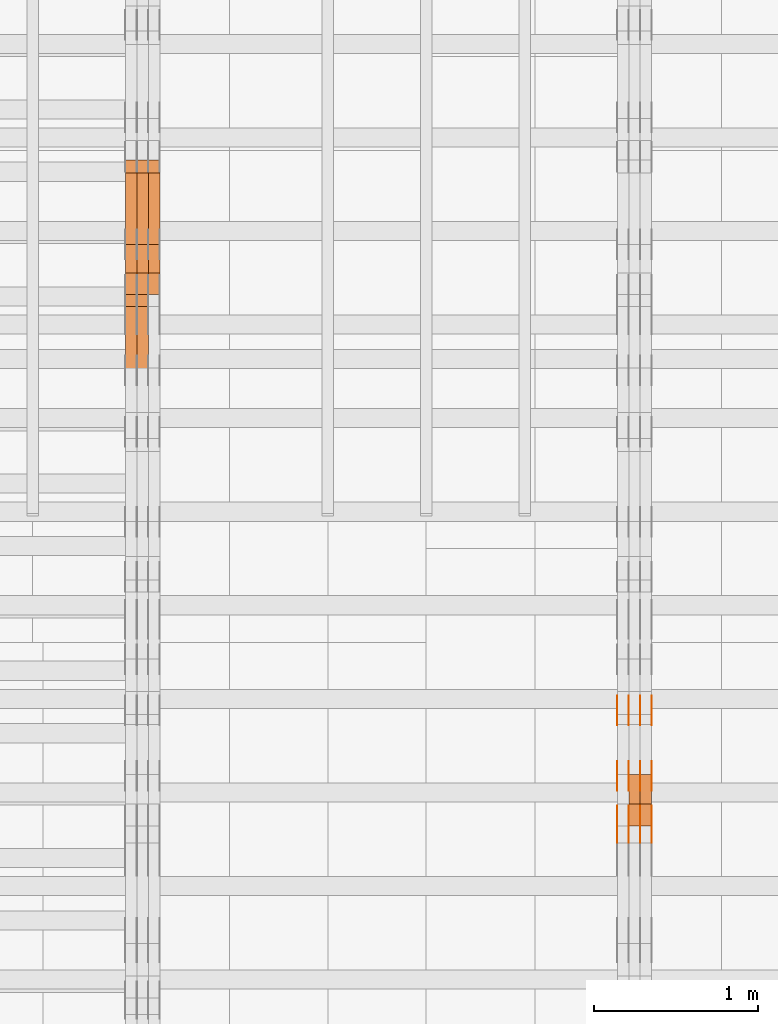
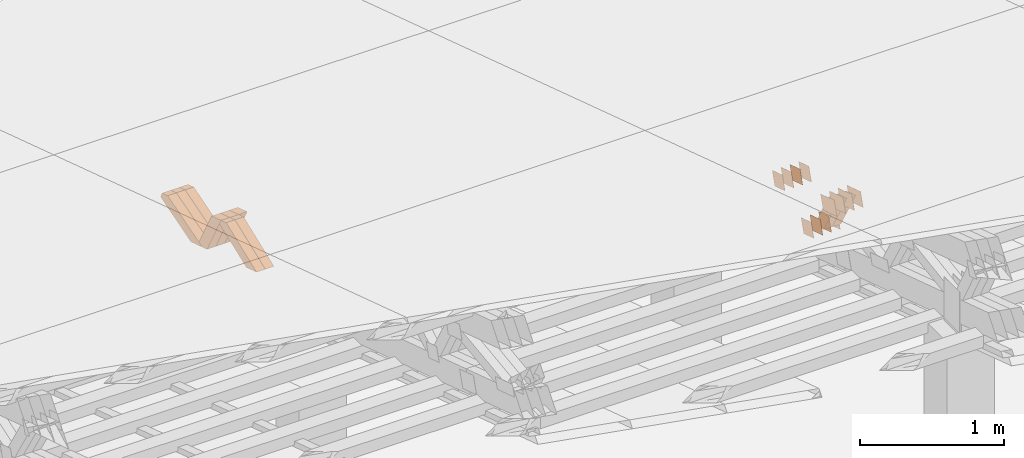
# One storey, part 177 of 385: 28 proxies.
"""IFC2X3 building model written with IfcOpenShell, lengths in millimetres."""

from ifc_helpers import new_model, entity, si_unit, converted_unit, derived_unit, direction, frame, origin, place, context, subcontext, project, spatial, polyline, outline, extrude, source, transform, mapped, material, type_object, type_shapes, element, save


model = new_model("IFC2X3")

# Units and contexts
model_context = context("Model", 3, precision=0.01, world=origin(), true_north=direction((6.12303176911189e-17, 1.0)))
body_context = subcontext(model_context, "Body", "Model", "MODEL_VIEW")
ifc_project = project(units=[si_unit("LENGTHUNIT", "METRE", prefix="MILLI"), si_unit("AREAUNIT", "SQUARE_METRE"), si_unit("VOLUMEUNIT", "CUBIC_METRE"), converted_unit("PLANEANGLEUNIT", "DEGREE", entity("IfcRatioMeasure", 0.0174532925199433), si_unit("PLANEANGLEUNIT", "RADIAN"), dimensions=[0, 0, 0, 0, 0, 0, 0]), si_unit("MASSUNIT", "GRAM", prefix="KILO"), derived_unit("MASSDENSITYUNIT", [(si_unit("MASSUNIT", "GRAM", prefix="KILO"), 1), (si_unit("LENGTHUNIT", "METRE"), -3)]), si_unit("TIMEUNIT", "SECOND"), si_unit("FREQUENCYUNIT", "HERTZ"), si_unit("THERMODYNAMICTEMPERATUREUNIT", "DEGREE_CELSIUS"), derived_unit("THERMALTRANSMITTANCEUNIT", [(si_unit("MASSUNIT", "GRAM", prefix="KILO"), 1), (si_unit("THERMODYNAMICTEMPERATUREUNIT", "KELVIN"), -1), (si_unit("TIMEUNIT", "SECOND"), -3)]), derived_unit("VOLUMETRICFLOWRATEUNIT", [(si_unit("LENGTHUNIT", "METRE"), 3), (si_unit("TIMEUNIT", "SECOND"), -1)]), si_unit("ELECTRICCURRENTUNIT", "AMPERE"), si_unit("ELECTRICVOLTAGEUNIT", "VOLT"), si_unit("POWERUNIT", "WATT"), si_unit("FORCEUNIT", "NEWTON", prefix="KILO"), si_unit("ILLUMINANCEUNIT", "LUX"), si_unit("LUMINOUSFLUXUNIT", "LUMEN"), si_unit("LUMINOUSINTENSITYUNIT", "CANDELA"), derived_unit("USERDEFINED", [(si_unit("MASSUNIT", "GRAM", prefix="KILO"), -1), (si_unit("LENGTHUNIT", "METRE"), -2), (si_unit("TIMEUNIT", "SECOND"), 3), (si_unit("LUMINOUSFLUXUNIT", "LUMEN"), 1)]), derived_unit("LINEARVELOCITYUNIT", [(si_unit("LENGTHUNIT", "METRE"), 1), (si_unit("TIMEUNIT", "SECOND"), -1)]), si_unit("PRESSUREUNIT", "PASCAL"), derived_unit("USERDEFINED", [(si_unit("LENGTHUNIT", "METRE"), -2), (si_unit("MASSUNIT", "GRAM", prefix="KILO"), 1), (si_unit("TIMEUNIT", "SECOND"), -2)])], contexts=[model_context])

# Site, building, storey
site_placement = place(None, origin())
site = spatial("IfcSite", under=ifc_project, at=site_placement, CompositionType="ELEMENT")
building_placement = place(site_placement, origin())
building = spatial("IfcBuilding", under=site, at=building_placement, CompositionType="ELEMENT")
storey_placement = place(building_placement, origin())
storey = spatial("IfcBuildingStorey", under=building, at=storey_placement, Name="Default", CompositionType="ELEMENT", Elevation=0.0)

# Proxies
ifc_material_1 = material(Name="IfcSurfaceStyle #107554")
building_element_proxy_type_1 = type_object("IfcBuildingElementProxyType", PredefinedType="NOTDEFINED", material=ifc_material_1)
shared_shape_1 = source(origin(), body_context, "Body", "SweptSolid", [
    extrude(outline(polyline([(-74.9998982809088, -60.000042563519), (74.9998377068237, -60.000042563519), (74.9998982809079, 60.0000425635189), (-74.9998377068227, 60.0000425635189), (-74.9998982809088, -60.000042563519)])), frame((75.0001050385304, 60.0001177331169, 0.0), z_axis=(0.0, 0.0, 1.0), x_axis=(-1.0, 0.0, 0.0)), (0.0, 0.0, 1.0), 1.3),
])
type_shapes(building_element_proxy_type_1, [shared_shape_1])
proxy_1_placement = place(building_placement, frame((6386.29999999999, 19806.7306653882, 2506.65203571776), z_axis=(-1.0, 0.0, 0.0), x_axis=(0.0, -0.951056516295154, 0.309016994374948)))
element("IfcBuildingElementProxy", 1, at=proxy_1_placement, inside=storey, type_object=building_element_proxy_type_1, material=ifc_material_1, context=body_context, shape_type="MappedRepresentation", body=[
    mapped(shared_shape_1, transform((0.0, 0.0, 0.0), scale=1.0)),
])
ifc_material_2 = material(Name="IfcSurfaceStyle #107497")
building_element_proxy_type_2 = type_object("IfcBuildingElementProxyType", PredefinedType="NOTDEFINED", material=ifc_material_2)
shared_shape_2 = source(origin(), body_context, "Body", "SweptSolid", [
    extrude(outline(polyline([(-74.9998982809088, -60.000042563519), (74.9998377068237, -60.000042563519), (74.9998982809079, 60.0000425635189), (-74.9998377068227, 60.0000425635189), (-74.9998982809088, -60.000042563519)])), frame((75.0001050385304, 60.0001177331169, 0.0), z_axis=(0.0, 0.0, 1.0), x_axis=(-1.0, 0.0, 0.0)), (0.0, 0.0, 1.0), 1.3),
])
type_shapes(building_element_proxy_type_2, [shared_shape_2])
proxy_2_placement = place(building_placement, frame((6315.0, 19806.7306653882, 2506.65203571776), z_axis=(-1.0, 0.0, 0.0), x_axis=(0.0, -0.951056516295154, 0.309016994374948)))
element("IfcBuildingElementProxy", 2, at=proxy_2_placement, inside=storey, type_object=building_element_proxy_type_2, material=ifc_material_2, context=body_context, shape_type="MappedRepresentation", body=[
    mapped(shared_shape_2, transform((0.0, 0.0, 0.0), scale=1.0)),
])
ifc_material_3 = material(Name="IfcSurfaceStyle #107440")
building_element_proxy_type_3 = type_object("IfcBuildingElementProxyType", PredefinedType="NOTDEFINED", material=ifc_material_3)
shared_shape_3 = source(origin(), body_context, "Body", "SweptSolid", [
    extrude(outline(polyline([(-74.9998982809088, -60.000042563519), (74.9998377068237, -60.000042563519), (74.9998982809079, 60.0000425635189), (-74.9998377068227, 60.0000425635189), (-74.9998982809088, -60.000042563519)])), frame((75.0001050385304, 60.0001177331169, 0.0), z_axis=(0.0, 0.0, 1.0), x_axis=(-1.0, 0.0, 0.0)), (0.0, 0.0, 1.0), 1.3),
])
type_shapes(building_element_proxy_type_3, [shared_shape_3])
proxy_3_placement = place(building_placement, frame((6316.29999999999, 19806.7306653882, 2506.65203571776), z_axis=(-1.0, 0.0, 0.0), x_axis=(0.0, -0.951056516295154, 0.309016994374948)))
element("IfcBuildingElementProxy", 3, at=proxy_3_placement, inside=storey, type_object=building_element_proxy_type_3, material=ifc_material_3, context=body_context, shape_type="MappedRepresentation", body=[
    mapped(shared_shape_3, transform((0.0, 0.0, 0.0), scale=1.0)),
])
ifc_material_4 = material(Name="IfcSurfaceStyle #107383")
building_element_proxy_type_4 = type_object("IfcBuildingElementProxyType", PredefinedType="NOTDEFINED", material=ifc_material_4)
shared_shape_4 = source(origin(), body_context, "Body", "SweptSolid", [
    extrude(outline(polyline([(-74.9998982809088, -60.000042563519), (74.9998377068237, -60.000042563519), (74.9998982809079, 60.0000425635189), (-74.9998377068227, 60.0000425635189), (-74.9998982809088, -60.000042563519)])), frame((75.0001050385304, 60.0001177331169, 0.0), z_axis=(0.0, 0.0, 1.0), x_axis=(-1.0, 0.0, 0.0)), (0.0, 0.0, 1.0), 1.29999999999999),
])
type_shapes(building_element_proxy_type_4, [shared_shape_4])
proxy_4_placement = place(building_placement, frame((6245.0, 19806.7306653882, 2506.65203571776), z_axis=(-1.0, 0.0, 0.0), x_axis=(0.0, -0.951056516295154, 0.309016994374948)))
element("IfcBuildingElementProxy", 4, at=proxy_4_placement, inside=storey, type_object=building_element_proxy_type_4, material=ifc_material_4, context=body_context, shape_type="MappedRepresentation", body=[
    mapped(shared_shape_4, transform((0.0, 0.0, 0.0), scale=1.0)),
])
ifc_material_5 = material(Name="IfcSurfaceStyle #107326")
building_element_proxy_type_5 = type_object("IfcBuildingElementProxyType", PredefinedType="NOTDEFINED", material=ifc_material_5)
shared_shape_5 = source(origin(), body_context, "Body", "SweptSolid", [
    extrude(outline(polyline([(-74.9998982809088, -60.000042563519), (74.9998377068237, -60.000042563519), (74.9998982809079, 60.0000425635189), (-74.9998377068227, 60.0000425635189), (-74.9998982809088, -60.000042563519)])), frame((75.0001050385304, 60.0001177331169, 0.0), z_axis=(0.0, 0.0, 1.0), x_axis=(-1.0, 0.0, 0.0)), (0.0, 0.0, 1.0), 1.29999999999999),
])
type_shapes(building_element_proxy_type_5, [shared_shape_5])
proxy_5_placement = place(building_placement, frame((6246.29999999999, 19806.7306653882, 2506.65203571776), z_axis=(-1.0, 0.0, 0.0), x_axis=(0.0, -0.951056516295154, 0.309016994374948)))
element("IfcBuildingElementProxy", 5, at=proxy_5_placement, inside=storey, type_object=building_element_proxy_type_5, material=ifc_material_5, context=body_context, shape_type="MappedRepresentation", body=[
    mapped(shared_shape_5, transform((0.0, 0.0, 0.0), scale=1.0)),
])
ifc_material_6 = material(Name="IfcSurfaceStyle #107269")
building_element_proxy_type_6 = type_object("IfcBuildingElementProxyType", PredefinedType="NOTDEFINED", material=ifc_material_6)
shared_shape_6 = source(origin(), body_context, "Body", "SweptSolid", [
    extrude(outline(polyline([(-74.9998982809088, -60.000042563519), (74.9998377068237, -60.000042563519), (74.9998982809079, 60.0000425635189), (-74.9998377068227, 60.0000425635189), (-74.9998982809088, -60.000042563519)])), frame((75.0001050385304, 60.0001177331169, 0.0), z_axis=(0.0, 0.0, 1.0), x_axis=(-1.0, 0.0, 0.0)), (0.0, 0.0, 1.0), 1.29999999999999),
])
type_shapes(building_element_proxy_type_6, [shared_shape_6])
proxy_6_placement = place(building_placement, frame((6175.0, 19806.7306653882, 2506.65203571776), z_axis=(-1.0, 0.0, 0.0), x_axis=(0.0, -0.951056516295154, 0.309016994374948)))
element("IfcBuildingElementProxy", 6, at=proxy_6_placement, inside=storey, type_object=building_element_proxy_type_6, material=ifc_material_6, context=body_context, shape_type="MappedRepresentation", body=[
    mapped(shared_shape_6, transform((0.0, 0.0, 0.0), scale=1.0)),
])
ifc_material_7 = material(Name="IfcSurfaceStyle #106186")
building_element_proxy_type_7 = type_object("IfcBuildingElementProxyType", PredefinedType="NOTDEFINED", material=ifc_material_7)
shared_shape_7 = source(origin(), body_context, "Body", "SweptSolid", [
    extrude(outline(polyline([(-99.9998479918963, -59.9999913366637), (99.9998251396114, -59.9999913366637), (99.9998102700952, 59.9999913366637), (-99.9997874178102, 59.9999913366637), (-99.9998479918963, -59.9999913366637)])), frame((99.9998251396114, 60.0000609537942, 0.0), z_axis=(0.0, 0.0, 1.0), x_axis=(-1.0, 0.0, 0.0)), (0.0, 0.0, 1.0), 1.3),
])
type_shapes(building_element_proxy_type_7, [shared_shape_7])
proxy_7_placement = place(building_placement, frame((6386.29999999999, 19136.9072023289, 2711.67346128215), z_axis=(-1.0, 0.0, 0.0), x_axis=(0.0, -0.951056516295154, 0.309016994374948)))
element("IfcBuildingElementProxy", 7, at=proxy_7_placement, inside=storey, type_object=building_element_proxy_type_7, material=ifc_material_7, context=body_context, shape_type="MappedRepresentation", body=[
    mapped(shared_shape_7, transform((0.0, 0.0, 0.0), scale=1.0)),
])
ifc_material_8 = material(Name="IfcSurfaceStyle #106129")
building_element_proxy_type_8 = type_object("IfcBuildingElementProxyType", PredefinedType="NOTDEFINED", material=ifc_material_8)
shared_shape_8 = source(origin(), body_context, "Body", "SweptSolid", [
    extrude(outline(polyline([(-99.9998479918963, -59.9999913366637), (99.9998251396114, -59.9999913366637), (99.9998102700952, 59.9999913366637), (-99.9997874178102, 59.9999913366637), (-99.9998479918963, -59.9999913366637)])), frame((99.9998251396114, 60.0000609537942, 0.0), z_axis=(0.0, 0.0, 1.0), x_axis=(-1.0, 0.0, 0.0)), (0.0, 0.0, 1.0), 1.3),
])
type_shapes(building_element_proxy_type_8, [shared_shape_8])
proxy_8_placement = place(building_placement, frame((6315.0, 19136.9072023289, 2711.67346128215), z_axis=(-1.0, 0.0, 0.0), x_axis=(0.0, -0.951056516295154, 0.309016994374948)))
element("IfcBuildingElementProxy", 8, at=proxy_8_placement, inside=storey, type_object=building_element_proxy_type_8, material=ifc_material_8, context=body_context, shape_type="MappedRepresentation", body=[
    mapped(shared_shape_8, transform((0.0, 0.0, 0.0), scale=1.0)),
])
ifc_material_9 = material(Name="IfcSurfaceStyle #106072")
building_element_proxy_type_9 = type_object("IfcBuildingElementProxyType", PredefinedType="NOTDEFINED", material=ifc_material_9)
shared_shape_9 = source(origin(), body_context, "Body", "SweptSolid", [
    extrude(outline(polyline([(-99.9998479918963, -59.9999913366637), (99.9998251396114, -59.9999913366637), (99.9998102700952, 59.9999913366637), (-99.9997874178102, 59.9999913366637), (-99.9998479918963, -59.9999913366637)])), frame((99.9998251396114, 60.0000609537942, 0.0), z_axis=(0.0, 0.0, 1.0), x_axis=(-1.0, 0.0, 0.0)), (0.0, 0.0, 1.0), 1.3),
])
type_shapes(building_element_proxy_type_9, [shared_shape_9])
proxy_9_placement = place(building_placement, frame((6316.29999999999, 19136.9072023289, 2711.67346128215), z_axis=(-1.0, 0.0, 0.0), x_axis=(0.0, -0.951056516295154, 0.309016994374948)))
element("IfcBuildingElementProxy", 9, at=proxy_9_placement, inside=storey, type_object=building_element_proxy_type_9, material=ifc_material_9, context=body_context, shape_type="MappedRepresentation", body=[
    mapped(shared_shape_9, transform((0.0, 0.0, 0.0), scale=1.0)),
])
ifc_material_10 = material(Name="IfcSurfaceStyle #106015")
building_element_proxy_type_10 = type_object("IfcBuildingElementProxyType", PredefinedType="NOTDEFINED", material=ifc_material_10)
shared_shape_10 = source(origin(), body_context, "Body", "SweptSolid", [
    extrude(outline(polyline([(-99.9998479918963, -59.9999913366637), (99.9998251396114, -59.9999913366637), (99.9998102700952, 59.9999913366637), (-99.9997874178102, 59.9999913366637), (-99.9998479918963, -59.9999913366637)])), frame((99.9998251396114, 60.0000609537942, 0.0), z_axis=(0.0, 0.0, 1.0), x_axis=(-1.0, 0.0, 0.0)), (0.0, 0.0, 1.0), 1.29999999999998),
])
type_shapes(building_element_proxy_type_10, [shared_shape_10])
proxy_10_placement = place(building_placement, frame((6245.0, 19136.9072023289, 2711.67346128215), z_axis=(-1.0, 0.0, 0.0), x_axis=(0.0, -0.951056516295154, 0.309016994374948)))
element("IfcBuildingElementProxy", 10, at=proxy_10_placement, inside=storey, type_object=building_element_proxy_type_10, material=ifc_material_10, context=body_context, shape_type="MappedRepresentation", body=[
    mapped(shared_shape_10, transform((0.0, 0.0, 0.0), scale=1.0)),
])
ifc_material_11 = material(Name="IfcSurfaceStyle #105958")
building_element_proxy_type_11 = type_object("IfcBuildingElementProxyType", PredefinedType="NOTDEFINED", material=ifc_material_11)
shared_shape_11 = source(origin(), body_context, "Body", "SweptSolid", [
    extrude(outline(polyline([(-99.9998479918963, -59.9999913366637), (99.9998251396114, -59.9999913366637), (99.9998102700952, 59.9999913366637), (-99.9997874178102, 59.9999913366637), (-99.9998479918963, -59.9999913366637)])), frame((99.9998251396114, 60.0000609537942, 0.0), z_axis=(0.0, 0.0, 1.0), x_axis=(-1.0, 0.0, 0.0)), (0.0, 0.0, 1.0), 1.29999999999998),
])
type_shapes(building_element_proxy_type_11, [shared_shape_11])
proxy_11_placement = place(building_placement, frame((6246.29999999999, 19136.9072023289, 2711.67346128215), z_axis=(-1.0, 0.0, 0.0), x_axis=(0.0, -0.951056516295154, 0.309016994374948)))
element("IfcBuildingElementProxy", 11, at=proxy_11_placement, inside=storey, type_object=building_element_proxy_type_11, material=ifc_material_11, context=body_context, shape_type="MappedRepresentation", body=[
    mapped(shared_shape_11, transform((0.0, 0.0, 0.0), scale=1.0)),
])
ifc_material_12 = material(Name="IfcSurfaceStyle #105901")
building_element_proxy_type_12 = type_object("IfcBuildingElementProxyType", PredefinedType="NOTDEFINED", material=ifc_material_12)
shared_shape_12 = source(origin(), body_context, "Body", "SweptSolid", [
    extrude(outline(polyline([(-99.9998479918963, -59.9999913366637), (99.9998251396114, -59.9999913366637), (99.9998102700952, 59.9999913366637), (-99.9997874178102, 59.9999913366637), (-99.9998479918963, -59.9999913366637)])), frame((99.9998251396114, 60.0000609537942, 0.0), z_axis=(0.0, 0.0, 1.0), x_axis=(-1.0, 0.0, 0.0)), (0.0, 0.0, 1.0), 1.29999999999999),
])
type_shapes(building_element_proxy_type_12, [shared_shape_12])
proxy_12_placement = place(building_placement, frame((6175.0, 19136.9072023289, 2711.67346128215), z_axis=(-1.0, 0.0, 0.0), x_axis=(0.0, -0.951056516295154, 0.309016994374948)))
element("IfcBuildingElementProxy", 12, at=proxy_12_placement, inside=storey, type_object=building_element_proxy_type_12, material=ifc_material_12, context=body_context, shape_type="MappedRepresentation", body=[
    mapped(shared_shape_12, transform((0.0, 0.0, 0.0), scale=1.0)),
])
ifc_material_13 = material(Name="IfcSurfaceStyle #101056")
building_element_proxy_type_13 = type_object("IfcBuildingElementProxyType", PredefinedType="NOTDEFINED", material=ifc_material_13)
shared_shape_13 = source(origin(), body_context, "Body", "SweptSolid", [
    extrude(outline(polyline([(-74.9998605591127, -59.9999264677599), (74.999875428618, -59.9999264677599), (74.9998605591127, 59.9999264677599), (-74.999875428618, 59.9999264677599), (-74.9998605591127, -59.9999264677599)])), frame((75.0002655673825, 60.0000016373433, 0.0), z_axis=(0.0, 0.0, 1.0), x_axis=(-1.0, 0.0, 0.0)), (0.0, 0.0, 1.0), 1.3),
])
type_shapes(building_element_proxy_type_13, [shared_shape_13])
proxy_13_placement = place(building_placement, frame((6386.29999999999, 19407.1136664358, 2348.71056820494), z_axis=(-1.0, 0.0, 0.0), x_axis=(0.0, -0.951056516295124, 0.309016994375039)))
element("IfcBuildingElementProxy", 13, at=proxy_13_placement, inside=storey, type_object=building_element_proxy_type_13, material=ifc_material_13, context=body_context, shape_type="MappedRepresentation", body=[
    mapped(shared_shape_13, transform((0.0, 0.0, 0.0), scale=1.0)),
])
ifc_material_14 = material(Name="IfcSurfaceStyle #100999")
building_element_proxy_type_14 = type_object("IfcBuildingElementProxyType", PredefinedType="NOTDEFINED", material=ifc_material_14)
shared_shape_14 = source(origin(), body_context, "Body", "SweptSolid", [
    extrude(outline(polyline([(-74.9998605591127, -59.9999264677599), (74.999875428618, -59.9999264677599), (74.9998605591127, 59.9999264677599), (-74.999875428618, 59.9999264677599), (-74.9998605591127, -59.9999264677599)])), frame((75.0002655673825, 60.0000016373433, 0.0), z_axis=(0.0, 0.0, 1.0), x_axis=(-1.0, 0.0, 0.0)), (0.0, 0.0, 1.0), 1.3),
])
type_shapes(building_element_proxy_type_14, [shared_shape_14])
proxy_14_placement = place(building_placement, frame((6315.0, 19407.1136664358, 2348.71056820494), z_axis=(-1.0, 0.0, 0.0), x_axis=(0.0, -0.951056516295124, 0.309016994375039)))
element("IfcBuildingElementProxy", 14, at=proxy_14_placement, inside=storey, type_object=building_element_proxy_type_14, material=ifc_material_14, context=body_context, shape_type="MappedRepresentation", body=[
    mapped(shared_shape_14, transform((0.0, 0.0, 0.0), scale=1.0)),
])
ifc_material_15 = material(Name="IfcSurfaceStyle #100942")
building_element_proxy_type_15 = type_object("IfcBuildingElementProxyType", PredefinedType="NOTDEFINED", material=ifc_material_15)
shared_shape_15 = source(origin(), body_context, "Body", "SweptSolid", [
    extrude(outline(polyline([(-74.9998605591127, -59.9999264677599), (74.999875428618, -59.9999264677599), (74.9998605591127, 59.9999264677599), (-74.999875428618, 59.9999264677599), (-74.9998605591127, -59.9999264677599)])), frame((75.0002655673825, 60.0000016373433, 0.0), z_axis=(0.0, 0.0, 1.0), x_axis=(-1.0, 0.0, 0.0)), (0.0, 0.0, 1.0), 1.3),
])
type_shapes(building_element_proxy_type_15, [shared_shape_15])
proxy_15_placement = place(building_placement, frame((6316.29999999999, 19407.1136664358, 2348.71056820494), z_axis=(-1.0, 0.0, 0.0), x_axis=(0.0, -0.951056516295124, 0.309016994375039)))
element("IfcBuildingElementProxy", 15, at=proxy_15_placement, inside=storey, type_object=building_element_proxy_type_15, material=ifc_material_15, context=body_context, shape_type="MappedRepresentation", body=[
    mapped(shared_shape_15, transform((0.0, 0.0, 0.0), scale=1.0)),
])
ifc_material_16 = material(Name="IfcSurfaceStyle #100885")
building_element_proxy_type_16 = type_object("IfcBuildingElementProxyType", PredefinedType="NOTDEFINED", material=ifc_material_16)
shared_shape_16 = source(origin(), body_context, "Body", "SweptSolid", [
    extrude(outline(polyline([(-74.9998605591127, -59.9999264677599), (74.999875428618, -59.9999264677599), (74.9998605591127, 59.9999264677599), (-74.999875428618, 59.9999264677599), (-74.9998605591127, -59.9999264677599)])), frame((75.0002655673825, 60.0000016373433, 0.0), z_axis=(0.0, 0.0, 1.0), x_axis=(-1.0, 0.0, 0.0)), (0.0, 0.0, 1.0), 1.29999999999999),
])
type_shapes(building_element_proxy_type_16, [shared_shape_16])
proxy_16_placement = place(building_placement, frame((6245.0, 19407.1136664358, 2348.71056820494), z_axis=(-1.0, 0.0, 0.0), x_axis=(0.0, -0.951056516295124, 0.309016994375039)))
element("IfcBuildingElementProxy", 16, at=proxy_16_placement, inside=storey, type_object=building_element_proxy_type_16, material=ifc_material_16, context=body_context, shape_type="MappedRepresentation", body=[
    mapped(shared_shape_16, transform((0.0, 0.0, 0.0), scale=1.0)),
])
ifc_material_17 = material(Name="IfcSurfaceStyle #100828")
building_element_proxy_type_17 = type_object("IfcBuildingElementProxyType", PredefinedType="NOTDEFINED", material=ifc_material_17)
shared_shape_17 = source(origin(), body_context, "Body", "SweptSolid", [
    extrude(outline(polyline([(-74.9998605591127, -59.9999264677599), (74.999875428618, -59.9999264677599), (74.9998605591127, 59.9999264677599), (-74.999875428618, 59.9999264677599), (-74.9998605591127, -59.9999264677599)])), frame((75.0002655673825, 60.0000016373433, 0.0), z_axis=(0.0, 0.0, 1.0), x_axis=(-1.0, 0.0, 0.0)), (0.0, 0.0, 1.0), 1.29999999999999),
])
type_shapes(building_element_proxy_type_17, [shared_shape_17])
proxy_17_placement = place(building_placement, frame((6246.29999999999, 19407.1136664358, 2348.71056820494), z_axis=(-1.0, 0.0, 0.0), x_axis=(0.0, -0.951056516295124, 0.309016994375039)))
element("IfcBuildingElementProxy", 17, at=proxy_17_placement, inside=storey, type_object=building_element_proxy_type_17, material=ifc_material_17, context=body_context, shape_type="MappedRepresentation", body=[
    mapped(shared_shape_17, transform((0.0, 0.0, 0.0), scale=1.0)),
])
ifc_material_18 = material(Name="IfcSurfaceStyle #100771")
building_element_proxy_type_18 = type_object("IfcBuildingElementProxyType", PredefinedType="NOTDEFINED", material=ifc_material_18)
shared_shape_18 = source(origin(), body_context, "Body", "SweptSolid", [
    extrude(outline(polyline([(-74.9998605591127, -59.9999264677599), (74.999875428618, -59.9999264677599), (74.9998605591127, 59.9999264677599), (-74.999875428618, 59.9999264677599), (-74.9998605591127, -59.9999264677599)])), frame((75.0002655673825, 60.0000016373433, 0.0), z_axis=(0.0, 0.0, 1.0), x_axis=(-1.0, 0.0, 0.0)), (0.0, 0.0, 1.0), 1.29999999999999),
])
type_shapes(building_element_proxy_type_18, [shared_shape_18])
proxy_18_placement = place(building_placement, frame((6175.0, 19407.1136664358, 2348.71056820494), z_axis=(-1.0, 0.0, 0.0), x_axis=(0.0, -0.951056516295124, 0.309016994375039)))
element("IfcBuildingElementProxy", 18, at=proxy_18_placement, inside=storey, type_object=building_element_proxy_type_18, material=ifc_material_18, context=body_context, shape_type="MappedRepresentation", body=[
    mapped(shared_shape_18, transform((0.0, 0.0, 0.0), scale=1.0)),
])
ifc_material_19 = material(Name="IfcSurfaceStyle #84298")
building_element_proxy_type_19 = type_object("IfcBuildingElementProxyType", Name="T1-W40 84296", PredefinedType="NOTDEFINED", material=ifc_material_19)
shared_shape_19 = source(origin(), body_context, "Body", "SweptSolid", [
    extrude(outline(polyline([(-190.697067347251, -47.4992767218045), (178.704677543904, -47.4992767218045), (178.119540532346, -0.000296092407564622), (126.935785980356, 47.4999913795318), (-293.062936709355, 47.4988581564849), (-190.697067347251, -47.4992767218045)])), frame((178.7049897723, 47.4999913795318, 0.0), z_axis=(0.0, 0.0, 1.0), x_axis=(-1.0, 0.0, 0.0)), (0.0, 0.0, 1.0), 70.0),
])
type_shapes(building_element_proxy_type_19, [shared_shape_19])
proxy_19_placement = place(building_placement, frame((6385.0, 19280.269490882, 2403.36730959494), z_axis=(-1.0, 0.0, 0.0), x_axis=(0.0, -0.48691092455798, 0.873451630913866)))
element("IfcBuildingElementProxy", 19, at=proxy_19_placement, inside=storey, type_object=building_element_proxy_type_19, material=ifc_material_19, Name="T1-W40", context=body_context, shape_type="MappedRepresentation", body=[
    mapped(shared_shape_19, transform((0.0, 0.0, 0.0), scale=1.0)),
])
ifc_material_20 = material(Name="IfcSurfaceStyle #84232")
building_element_proxy_type_20 = type_object("IfcBuildingElementProxyType", Name="T1-W40 84230", PredefinedType="NOTDEFINED", material=ifc_material_20)
shared_shape_20 = source(origin(), body_context, "Body", "SweptSolid", [
    extrude(outline(polyline([(-190.697067347251, -47.4992767218045), (178.704677543904, -47.4992767218045), (178.119540532346, -0.000296092407564622), (126.935785980356, 47.4999913795318), (-293.062936709355, 47.4988581564849), (-190.697067347251, -47.4992767218045)])), frame((178.7049897723, 47.4999913795318, 0.0), z_axis=(0.0, 0.0, 1.0), x_axis=(-1.0, 0.0, 0.0)), (0.0, 0.0, 1.0), 70.0),
])
type_shapes(building_element_proxy_type_20, [shared_shape_20])
proxy_20_placement = place(building_placement, frame((6315.0, 19280.269490882, 2403.36730959494), z_axis=(-1.0, 0.0, 0.0), x_axis=(0.0, -0.48691092455798, 0.873451630913866)))
element("IfcBuildingElementProxy", 20, at=proxy_20_placement, inside=storey, type_object=building_element_proxy_type_20, material=ifc_material_20, Name="T1-W40", context=body_context, shape_type="MappedRepresentation", body=[
    mapped(shared_shape_20, transform((0.0, 0.0, 0.0), scale=1.0)),
])
ifc_material_21 = material(Name="IfcSurfaceStyle #47028")
building_element_proxy_type_21 = type_object("IfcBuildingElementProxyType", Name="T1-W30 47026", PredefinedType="NOTDEFINED", material=ifc_material_21)
shared_shape_21 = source(origin(), body_context, "Body", "SweptSolid", [
    extrude(outline(polyline([(-319.322304176575, -47.5000259045904), (133.154090927094, -47.5000259045904), (191.489196707701, 6.99403755251016e-06), (197.330697834052, 47.5000224075717), (-202.651681292271, 47.5000224075717), (-319.322304176575, -47.5000259045904)])), frame((197.330834478517, 47.5000608592405, 0.0), z_axis=(0.0, 0.0, 1.0), x_axis=(-1.0, 0.0, 0.0)), (0.0, 0.0, 1.0), 70.0),
])
type_shapes(building_element_proxy_type_21, [shared_shape_21])
proxy_21_placement = place(building_placement, frame((3315.0, 22312.5352975627, 1720.70362673362), z_axis=(-1.0, 0.0, 0.0), x_axis=(0.0, -0.932610696879359, -0.360884036868072)))
element("IfcBuildingElementProxy", 21, at=proxy_21_placement, inside=storey, type_object=building_element_proxy_type_21, material=ifc_material_21, Name="T1-W30", context=body_context, shape_type="MappedRepresentation", body=[
    mapped(shared_shape_21, transform((0.0, 0.0, 0.0), scale=1.0)),
])
ifc_material_22 = material(Name="IfcSurfaceStyle #46962")
building_element_proxy_type_22 = type_object("IfcBuildingElementProxyType", Name="T1-W30 46960", PredefinedType="NOTDEFINED", material=ifc_material_22)
shared_shape_22 = source(origin(), body_context, "Body", "SweptSolid", [
    extrude(outline(polyline([(-319.322304176575, -47.5000259045904), (133.154090927094, -47.5000259045904), (191.489196707701, 6.99403755251016e-06), (197.330697834052, 47.5000224075717), (-202.651681292271, 47.5000224075717), (-319.322304176575, -47.5000259045904)])), frame((197.330834478517, 47.5000608592405, 0.0), z_axis=(0.0, 0.0, 1.0), x_axis=(-1.0, 0.0, 0.0)), (0.0, 0.0, 1.0), 70.0),
])
type_shapes(building_element_proxy_type_22, [shared_shape_22])
proxy_22_placement = place(building_placement, frame((3245.0, 22312.5352975627, 1720.70362673362), z_axis=(-1.0, 0.0, 0.0), x_axis=(0.0, -0.932610696879359, -0.360884036868072)))
element("IfcBuildingElementProxy", 22, at=proxy_22_placement, inside=storey, type_object=building_element_proxy_type_22, material=ifc_material_22, Name="T1-W30", context=body_context, shape_type="MappedRepresentation", body=[
    mapped(shared_shape_22, transform((0.0, 0.0, 0.0), scale=1.0)),
])
ifc_material_23 = material(Name="IfcSurfaceStyle #46698")
building_element_proxy_type_23 = type_object("IfcBuildingElementProxyType", Name="T1-W41 46696", PredefinedType="NOTDEFINED", material=ifc_material_23)
shared_shape_23 = source(origin(), body_context, "Body", "SweptSolid", [
    extrude(outline(polyline([(-190.064783497519, -47.5001011048749), (182.590736871656, -47.5001011048749), (172.978793750747, 0.000111395300689243), (123.505951450908, 47.5000454072246), (-289.010698575792, 47.5000454072246), (-190.064783497519, -47.5001011048749)])), frame((182.590736871656, 47.5001973817447, 0.0), z_axis=(0.0, 0.0, 1.0), x_axis=(-1.0, 0.0, 0.0)), (0.0, 0.0, 1.0), 70.0),
])
type_shapes(building_element_proxy_type_23, [shared_shape_23])
proxy_23_placement = place(building_placement, frame((3385.0, 22512.5506969063, 1347.13648051689), z_axis=(-1.0, 0.0, 0.0), x_axis=(0.0, -0.472020158706979, 0.881587755004706)))
element("IfcBuildingElementProxy", 23, at=proxy_23_placement, inside=storey, type_object=building_element_proxy_type_23, material=ifc_material_23, Name="T1-W41", context=body_context, shape_type="MappedRepresentation", body=[
    mapped(shared_shape_23, transform((0.0, 0.0, 0.0), scale=1.0)),
])
ifc_material_24 = material(Name="IfcSurfaceStyle #46632")
building_element_proxy_type_24 = type_object("IfcBuildingElementProxyType", Name="T1-W41 46630", PredefinedType="NOTDEFINED", material=ifc_material_24)
shared_shape_24 = source(origin(), body_context, "Body", "SweptSolid", [
    extrude(outline(polyline([(-190.064783497519, -47.5001011048749), (182.590736871656, -47.5001011048749), (172.978793750747, 0.000111395300689243), (123.505951450908, 47.5000454072246), (-289.010698575792, 47.5000454072246), (-190.064783497519, -47.5001011048749)])), frame((182.590736871656, 47.5001973817447, 0.0), z_axis=(0.0, 0.0, 1.0), x_axis=(-1.0, 0.0, 0.0)), (0.0, 0.0, 1.0), 70.0),
])
type_shapes(building_element_proxy_type_24, [shared_shape_24])
proxy_24_placement = place(building_placement, frame((3315.0, 22512.5506969063, 1347.13648051689), z_axis=(-1.0, 0.0, 0.0), x_axis=(0.0, -0.472020158706979, 0.881587755004706)))
element("IfcBuildingElementProxy", 24, at=proxy_24_placement, inside=storey, type_object=building_element_proxy_type_24, material=ifc_material_24, Name="T1-W41", context=body_context, shape_type="MappedRepresentation", body=[
    mapped(shared_shape_24, transform((0.0, 0.0, 0.0), scale=1.0)),
])
ifc_material_25 = material(Name="IfcSurfaceStyle #46566")
building_element_proxy_type_25 = type_object("IfcBuildingElementProxyType", Name="T1-W41 46564", PredefinedType="NOTDEFINED", material=ifc_material_25)
shared_shape_25 = source(origin(), body_context, "Body", "SweptSolid", [
    extrude(outline(polyline([(-190.064783497519, -47.5001011048749), (182.590736871656, -47.5001011048749), (172.978793750747, 0.000111395300689243), (123.505951450908, 47.5000454072246), (-289.010698575792, 47.5000454072246), (-190.064783497519, -47.5001011048749)])), frame((182.590736871656, 47.5001973817447, 0.0), z_axis=(0.0, 0.0, 1.0), x_axis=(-1.0, 0.0, 0.0)), (0.0, 0.0, 1.0), 70.0),
])
type_shapes(building_element_proxy_type_25, [shared_shape_25])
proxy_25_placement = place(building_placement, frame((3245.0, 22512.5506969063, 1347.13648051689), z_axis=(-1.0, 0.0, 0.0), x_axis=(0.0, -0.472020158706979, 0.881587755004706)))
element("IfcBuildingElementProxy", 25, at=proxy_25_placement, inside=storey, type_object=building_element_proxy_type_25, material=ifc_material_25, Name="T1-W41", context=body_context, shape_type="MappedRepresentation", body=[
    mapped(shared_shape_25, transform((0.0, 0.0, 0.0), scale=1.0)),
])
ifc_material_26 = material(Name="IfcSurfaceStyle #46302")
building_element_proxy_type_26 = type_object("IfcBuildingElementProxyType", Name="T1-W23 46300", PredefinedType="NOTDEFINED", material=ifc_material_26)
shared_shape_26 = source(origin(), body_context, "Body", "SweptSolid", [
    extrude(outline(polyline([(-356.808656505462, -47.5000180192671), (144.726334557508, -47.5000180192671), (213.258834104997, -2.90494310381195e-05), (218.567145253444, 47.5000325439826), (-219.743657410487, 47.5000325439827), (-356.808656505462, -47.5000180192671)])), frame((218.567145253444, 47.5000325439826, 0.0), z_axis=(0.0, 0.0, 1.0), x_axis=(-1.0, 0.0, 0.0)), (0.0, 0.0, 1.0), 70.0),
])
type_shapes(building_element_proxy_type_26, [shared_shape_26])
proxy_26_placement = place(building_placement, frame((3385.0, 23128.2626953125, 1452.63940429688), z_axis=(-1.0, 0.0, 0.0), x_axis=(0.0, -0.957692700226705, -0.287792793399143)))
element("IfcBuildingElementProxy", 26, at=proxy_26_placement, inside=storey, type_object=building_element_proxy_type_26, material=ifc_material_26, Name="T1-W23", context=body_context, shape_type="MappedRepresentation", body=[
    mapped(shared_shape_26, transform((0.0, 0.0, 0.0), scale=1.0)),
])
ifc_material_27 = material(Name="IfcSurfaceStyle #46236")
building_element_proxy_type_27 = type_object("IfcBuildingElementProxyType", Name="T1-W23 46234", PredefinedType="NOTDEFINED", material=ifc_material_27)
shared_shape_27 = source(origin(), body_context, "Body", "SweptSolid", [
    extrude(outline(polyline([(-356.808656505462, -47.5000180192671), (144.726334557508, -47.5000180192671), (213.258834104997, -2.90494310381195e-05), (218.567145253444, 47.5000325439826), (-219.743657410487, 47.5000325439827), (-356.808656505462, -47.5000180192671)])), frame((218.567145253444, 47.5000325439826, 0.0), z_axis=(0.0, 0.0, 1.0), x_axis=(-1.0, 0.0, 0.0)), (0.0, 0.0, 1.0), 70.0),
])
type_shapes(building_element_proxy_type_27, [shared_shape_27])
proxy_27_placement = place(building_placement, frame((3315.0, 23128.2626953125, 1452.63940429688), z_axis=(-1.0, 0.0, 0.0), x_axis=(0.0, -0.957692700226705, -0.287792793399143)))
element("IfcBuildingElementProxy", 27, at=proxy_27_placement, inside=storey, type_object=building_element_proxy_type_27, material=ifc_material_27, Name="T1-W23", context=body_context, shape_type="MappedRepresentation", body=[
    mapped(shared_shape_27, transform((0.0, 0.0, 0.0), scale=1.0)),
])
ifc_material_28 = material(Name="IfcSurfaceStyle #46170")
building_element_proxy_type_28 = type_object("IfcBuildingElementProxyType", Name="T1-W23 46168", PredefinedType="NOTDEFINED", material=ifc_material_28)
shared_shape_28 = source(origin(), body_context, "Body", "SweptSolid", [
    extrude(outline(polyline([(-356.808656505462, -47.5000180192671), (144.726334557508, -47.5000180192671), (213.258834104997, -2.90494310381195e-05), (218.567145253444, 47.5000325439826), (-219.743657410487, 47.5000325439827), (-356.808656505462, -47.5000180192671)])), frame((218.567145253444, 47.5000325439826, 0.0), z_axis=(0.0, 0.0, 1.0), x_axis=(-1.0, 0.0, 0.0)), (0.0, 0.0, 1.0), 70.0),
])
type_shapes(building_element_proxy_type_28, [shared_shape_28])
proxy_28_placement = place(building_placement, frame((3245.0, 23128.2626953125, 1452.63940429688), z_axis=(-1.0, 0.0, 0.0), x_axis=(0.0, -0.957692700226705, -0.287792793399143)))
element("IfcBuildingElementProxy", 28, at=proxy_28_placement, inside=storey, type_object=building_element_proxy_type_28, material=ifc_material_28, Name="T1-W23", context=body_context, shape_type="MappedRepresentation", body=[
    mapped(shared_shape_28, transform((0.0, 0.0, 0.0), scale=1.0)),
])

save(model, "model.ifc")
